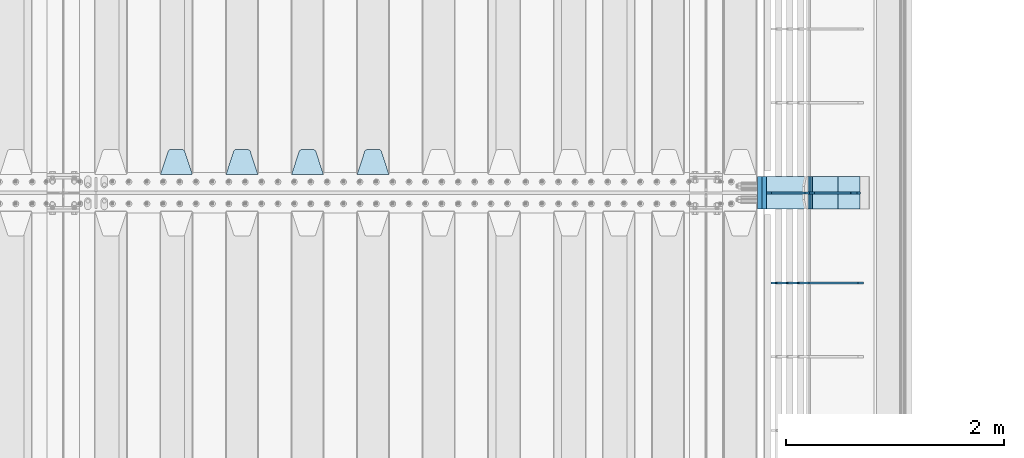
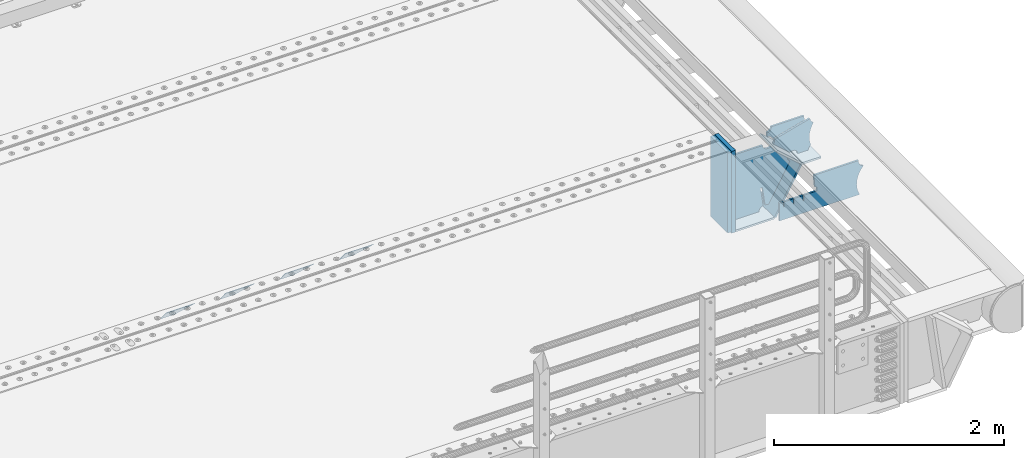
# One storey, part 244 of 270: 14 plates.
"""IFC2X3 building model written with IfcOpenShell, lengths in millimetres."""

from ifc_helpers import new_model, si_unit, frame, origin_with_axes, place, context, subcontext, project, spatial, faceted_brep, material, type_object, element, save


model = new_model("IFC2X3")

# Units and contexts
model_context = context("Model", 3, precision=1e-05, world=origin_with_axes())
body_context = subcontext(model_context, "Body", "Model", "MODEL_VIEW")
ifc_project = project(units=[si_unit("LENGTHUNIT", "METRE", prefix="MILLI"), si_unit("AREAUNIT", "SQUARE_METRE"), si_unit("VOLUMEUNIT", "CUBIC_METRE"), si_unit("MASSUNIT", "GRAM", prefix="KILO"), si_unit("TIMEUNIT", "SECOND"), si_unit("PLANEANGLEUNIT", "RADIAN"), si_unit("SOLIDANGLEUNIT", "STERADIAN"), si_unit("THERMODYNAMICTEMPERATUREUNIT", "DEGREE_CELSIUS"), si_unit("LUMINOUSINTENSITYUNIT", "LUMEN")], contexts=[model_context])

# Site, building, storey
site_placement = place(None, origin_with_axes())
site = spatial("IfcSite", under=ifc_project, at=site_placement, CompositionType="ELEMENT")
building_placement = place(site_placement, origin_with_axes())
building = spatial("IfcBuilding", under=site, at=building_placement, Name="Standard", CompositionType="ELEMENT")
storey_placement = place(building_placement, origin_with_axes())
storey = spatial("IfcBuildingStorey", under=building, at=storey_placement, Name="Undefined", CompositionType="ELEMENT", Elevation=0.0)

# Plates
ifc_material_1 = material(Name="STEEL/S355N")
plate_type_1 = type_object("IfcPlateType", PredefinedType="NOTDEFINED")
plate_1_placement = place(storey_placement, frame((17015.0, -20831.767766953, -1.76776695296758), z_axis=(0.0, 0.707106781186547, -0.707106781186548), x_axis=(-1.0, 0.0, 0.0)))
element("IfcPlate", 1, at=plate_1_placement, inside=storey, type_object=plate_type_1, material=ifc_material_1, context=body_context, shape_type="Brep", body=[
    faceted_brep([(0.0, -2.5, 0.0), (69.345504679477, -2.5, 300.171731424831), (69.345504679477, 2.5, 300.171731424831), (0.0, 2.5, 0.0), (70.9274061199576, -2.5, 304.8974424154), (70.9274061199576, 2.5, 304.8974424154), (73.3818627772307, -2.49999999999818, 309.234538108527), (73.3818627772307, 2.50000000000182, 309.234538108527), (76.6187032999551, -2.5, 313.023683126103), (76.6187032999551, 2.5, 313.023683126103), (80.5190132704993, -2.5, 316.125672595372), (80.5190132704993, 2.50000000000182, 316.125672595372), (84.9395038596849, -2.49999999999818, 318.426546230476), (84.9395038596849, 2.5, 318.426546230476), (89.7177759439219, -2.49999999999818, 319.841774983275), (89.7177759439219, 2.50000000000182, 319.841774983275), (94.678286292652, -2.5, 320.319366455078), (94.678286292652, 2.5, 320.319366455078), (195.321713707348, -2.5, 320.319366455078), (195.321713707348, 2.5, 320.319366455078), (200.282224056078, -2.49999999999818, 319.841774983275), (200.282224056078, 2.50000000000182, 319.841774983275), (205.060496140315, -2.5, 318.426546230476), (205.060496140315, 2.5, 318.426546230476), (209.480986729501, -2.5, 316.12567259537), (209.480986729501, 2.50000000000182, 316.12567259537), (213.381296700045, -2.5, 313.023683126103), (213.381296700045, 2.5, 313.023683126103), (216.618137222769, -2.49999999999818, 309.234538108525), (216.618137222769, 2.50000000000182, 309.234538108527), (219.072593880042, -2.49999999999818, 304.897442415398), (219.072593880042, 2.50000000000182, 304.897442415397), (220.654495320523, -2.5, 300.171731424831), (220.654495320523, 2.5, 300.171731424831), (290.0, -2.49999999999818, 0.0), (290.0, 2.5, 0.0)], [[[0, 1, 2, 3]], [[1, 4, 5, 2]], [[4, 6, 7, 5]], [[6, 8, 9, 7]], [[8, 10, 11, 9]], [[10, 12, 13, 11]], [[12, 14, 15, 13]], [[14, 16, 17, 15]], [[16, 18, 19, 17]], [[18, 20, 21, 19]], [[20, 22, 23, 21]], [[22, 24, 25, 23]], [[24, 26, 27, 25]], [[26, 28, 29, 27]], [[28, 30, 31, 29]], [[30, 32, 33, 31]], [[32, 34, 35, 33]], [[34, 0, 3, 35]], [[5, 7, 9, 11, 13, 15, 17, 19, 21, 23, 25, 27, 29, 31, 33, 35, 3, 2]], [[34, 32, 30, 28, 26, 24, 22, 20, 18, 16, 14, 12, 10, 8, 6, 4, 1, 0]]]),
])
plate_2_placement = place(storey_placement, frame((16415.0, -20831.767766953, -1.76776695296758), z_axis=(0.0, 0.707106781186547, -0.707106781186548), x_axis=(-1.0, 0.0, 0.0)))
element("IfcPlate", 2, at=plate_2_placement, inside=storey, type_object=plate_type_1, material=ifc_material_1, context=body_context, shape_type="Brep", body=[
    faceted_brep([(0.0, -2.5, 0.0), (69.345504679477, -2.5, 300.171731424831), (69.345504679477, 2.5, 300.171731424831), (0.0, 2.5, 0.0), (70.9274061199576, -2.5, 304.8974424154), (70.9274061199576, 2.5, 304.8974424154), (73.3818627772307, -2.49999999999818, 309.234538108527), (73.3818627772307, 2.50000000000182, 309.234538108527), (76.6187032999551, -2.5, 313.023683126103), (76.6187032999551, 2.5, 313.023683126103), (80.5190132704993, -2.5, 316.125672595372), (80.5190132704993, 2.50000000000182, 316.125672595372), (84.9395038596849, -2.49999999999818, 318.426546230476), (84.9395038596849, 2.5, 318.426546230476), (89.7177759439219, -2.49999999999818, 319.841774983275), (89.7177759439219, 2.50000000000182, 319.841774983275), (94.678286292652, -2.5, 320.319366455078), (94.678286292652, 2.5, 320.319366455078), (195.321713707348, -2.5, 320.319366455078), (195.321713707348, 2.5, 320.319366455078), (200.282224056078, -2.49999999999818, 319.841774983275), (200.282224056078, 2.50000000000182, 319.841774983275), (205.060496140315, -2.5, 318.426546230476), (205.060496140315, 2.5, 318.426546230476), (209.480986729501, -2.5, 316.12567259537), (209.480986729501, 2.50000000000182, 316.12567259537), (213.381296700045, -2.5, 313.023683126103), (213.381296700045, 2.5, 313.023683126103), (216.618137222769, -2.49999999999818, 309.234538108525), (216.618137222769, 2.50000000000182, 309.234538108527), (219.072593880042, -2.49999999999818, 304.897442415398), (219.072593880042, 2.50000000000182, 304.897442415397), (220.654495320523, -2.5, 300.171731424831), (220.654495320523, 2.5, 300.171731424831), (290.0, -2.49999999999818, 0.0), (290.0, 2.5, 0.0)], [[[0, 1, 2, 3]], [[1, 4, 5, 2]], [[4, 6, 7, 5]], [[6, 8, 9, 7]], [[8, 10, 11, 9]], [[10, 12, 13, 11]], [[12, 14, 15, 13]], [[14, 16, 17, 15]], [[16, 18, 19, 17]], [[18, 20, 21, 19]], [[20, 22, 23, 21]], [[22, 24, 25, 23]], [[24, 26, 27, 25]], [[26, 28, 29, 27]], [[28, 30, 31, 29]], [[30, 32, 33, 31]], [[32, 34, 35, 33]], [[34, 0, 3, 35]], [[5, 7, 9, 11, 13, 15, 17, 19, 21, 23, 25, 27, 29, 31, 33, 35, 3, 2]], [[34, 32, 30, 28, 26, 24, 22, 20, 18, 16, 14, 12, 10, 8, 6, 4, 1, 0]]]),
])
plate_3_placement = place(storey_placement, frame((15815.0, -20831.767766953, -1.76776695296758), z_axis=(0.0, 0.707106781186547, -0.707106781186548), x_axis=(-1.0, 0.0, 0.0)))
element("IfcPlate", 3, at=plate_3_placement, inside=storey, type_object=plate_type_1, material=ifc_material_1, context=body_context, shape_type="Brep", body=[
    faceted_brep([(0.0, -2.5, 0.0), (69.345504679477, -2.5, 300.171731424831), (69.345504679477, 2.5, 300.171731424831), (0.0, 2.5, 0.0), (70.9274061199576, -2.5, 304.8974424154), (70.9274061199576, 2.5, 304.8974424154), (73.3818627772307, -2.49999999999818, 309.234538108527), (73.3818627772307, 2.50000000000182, 309.234538108527), (76.6187032999551, -2.5, 313.023683126103), (76.6187032999551, 2.5, 313.023683126103), (80.5190132704993, -2.5, 316.125672595372), (80.5190132704993, 2.50000000000182, 316.125672595372), (84.9395038596849, -2.49999999999818, 318.426546230476), (84.9395038596849, 2.5, 318.426546230476), (89.7177759439219, -2.49999999999818, 319.841774983275), (89.7177759439219, 2.50000000000182, 319.841774983275), (94.678286292652, -2.5, 320.319366455078), (94.678286292652, 2.5, 320.319366455078), (195.321713707348, -2.5, 320.319366455078), (195.321713707348, 2.5, 320.319366455078), (200.282224056078, -2.49999999999818, 319.841774983275), (200.282224056078, 2.50000000000182, 319.841774983275), (205.060496140315, -2.5, 318.426546230476), (205.060496140315, 2.5, 318.426546230476), (209.480986729501, -2.5, 316.12567259537), (209.480986729501, 2.50000000000182, 316.12567259537), (213.381296700045, -2.5, 313.023683126103), (213.381296700045, 2.5, 313.023683126103), (216.618137222769, -2.49999999999818, 309.234538108525), (216.618137222769, 2.50000000000182, 309.234538108527), (219.072593880042, -2.49999999999818, 304.897442415398), (219.072593880042, 2.50000000000182, 304.897442415397), (220.654495320523, -2.5, 300.171731424831), (220.654495320523, 2.5, 300.171731424831), (290.0, -2.49999999999818, 0.0), (290.0, 2.5, 0.0)], [[[0, 1, 2, 3]], [[1, 4, 5, 2]], [[4, 6, 7, 5]], [[6, 8, 9, 7]], [[8, 10, 11, 9]], [[10, 12, 13, 11]], [[12, 14, 15, 13]], [[14, 16, 17, 15]], [[16, 18, 19, 17]], [[18, 20, 21, 19]], [[20, 22, 23, 21]], [[22, 24, 25, 23]], [[24, 26, 27, 25]], [[26, 28, 29, 27]], [[28, 30, 31, 29]], [[30, 32, 33, 31]], [[32, 34, 35, 33]], [[34, 0, 3, 35]], [[5, 7, 9, 11, 13, 15, 17, 19, 21, 23, 25, 27, 29, 31, 33, 35, 3, 2]], [[34, 32, 30, 28, 26, 24, 22, 20, 18, 16, 14, 12, 10, 8, 6, 4, 1, 0]]]),
])
plate_4_placement = place(storey_placement, frame((15215.0, -20831.767766953, -1.76776695296758), z_axis=(0.0, 0.707106781186547, -0.707106781186548), x_axis=(-1.0, 0.0, 0.0)))
element("IfcPlate", 4, at=plate_4_placement, inside=storey, type_object=plate_type_1, material=ifc_material_1, context=body_context, shape_type="Brep", body=[
    faceted_brep([(0.0, -2.5, 0.0), (69.345504679477, -2.5, 300.171731424831), (69.345504679477, 2.5, 300.171731424831), (0.0, 2.5, 0.0), (70.9274061199576, -2.5, 304.8974424154), (70.9274061199576, 2.5, 304.8974424154), (73.3818627772307, -2.49999999999818, 309.234538108527), (73.3818627772307, 2.50000000000182, 309.234538108527), (76.6187032999551, -2.5, 313.023683126103), (76.6187032999551, 2.5, 313.023683126103), (80.5190132704993, -2.5, 316.125672595372), (80.5190132704993, 2.50000000000182, 316.125672595372), (84.9395038596849, -2.49999999999818, 318.426546230476), (84.9395038596849, 2.5, 318.426546230476), (89.7177759439219, -2.49999999999818, 319.841774983275), (89.7177759439219, 2.50000000000182, 319.841774983275), (94.678286292652, -2.5, 320.319366455078), (94.678286292652, 2.5, 320.319366455078), (195.321713707348, -2.5, 320.319366455078), (195.321713707348, 2.5, 320.319366455078), (200.282224056078, -2.49999999999818, 319.841774983275), (200.282224056078, 2.50000000000182, 319.841774983275), (205.060496140315, -2.5, 318.426546230476), (205.060496140315, 2.5, 318.426546230476), (209.480986729501, -2.5, 316.12567259537), (209.480986729501, 2.50000000000182, 316.12567259537), (213.381296700045, -2.5, 313.023683126103), (213.381296700045, 2.5, 313.023683126103), (216.618137222769, -2.49999999999818, 309.234538108525), (216.618137222769, 2.50000000000182, 309.234538108527), (219.072593880042, -2.49999999999818, 304.897442415398), (219.072593880042, 2.50000000000182, 304.897442415397), (220.654495320523, -2.5, 300.171731424831), (220.654495320523, 2.5, 300.171731424831), (290.0, -2.49999999999818, 0.0), (290.0, 2.5, 0.0)], [[[0, 1, 2, 3]], [[1, 4, 5, 2]], [[4, 6, 7, 5]], [[6, 8, 9, 7]], [[8, 10, 11, 9]], [[10, 12, 13, 11]], [[12, 14, 15, 13]], [[14, 16, 17, 15]], [[16, 18, 19, 17]], [[18, 20, 21, 19]], [[20, 22, 23, 21]], [[22, 24, 25, 23]], [[24, 26, 27, 25]], [[26, 28, 29, 27]], [[28, 30, 31, 29]], [[30, 32, 33, 31]], [[32, 34, 35, 33]], [[34, 0, 3, 35]], [[5, 7, 9, 11, 13, 15, 17, 19, 21, 23, 25, 27, 29, 31, 33, 35, 3, 2]], [[34, 32, 30, 28, 26, 24, 22, 20, 18, 16, 14, 12, 10, 8, 6, 4, 1, 0]]]),
])
plate_type_2 = type_object("IfcPlateType", PredefinedType="NOTDEFINED")
plate_5_placement = place(storey_placement, frame((20872.9988298914, -20999.9999999999, -179.999999999866), z_axis=(0.0, 0.0, -1.0), x_axis=(-1.0, 0.0, 0.0)))
element("IfcPlate", 5, at=plate_5_placement, inside=storey, type_object=plate_type_2, material=ifc_material_1, context=body_context, shape_type="Brep", body=[
    faceted_brep([(46.0258547361445, 10.0, 641.078828352486), (73.3015011074785, 10.0000000000073, 445.179898435767), (73.3015011074785, -9.99999999998909, 445.179898435767), (46.0258547361445, -10.0, 641.078828352486), (53.4925862871278, 10.0000000000073, 442.421838675718), (53.4925862871278, -9.99999999998909, 442.421838675718), (25.7820501123933, 10.0, 641.444230671287), (25.7820501123933, -10.0, 641.444230671287), (54.6652503111618, 10.0, 642.447174185377), (54.6652503111618, -10.0, 642.447174185377), (68.6036632070354, -10.0, 649.549150281387), (68.6036632070354, 10.0, 649.549150281387), (79.6652503111618, -10.0, 660.610737385511), (79.6652503111618, 10.0, 660.610737385511), (86.7672264071698, -10.0, 674.549150281387), (86.7672264071698, 10.0, 674.549150281387), (89.2144005924129, -10.0, 690.0), (89.2144005924129, 10.0, 690.0), (353.0, -10.0, 690.0), (353.0, 10.0, 690.0), (355.447174185243, -10.0, 674.549150281253), (355.447174185243, 10.0, 674.549150281253), (362.549150281251, -10.0, 660.610737385376), (362.549150281251, 10.0, 660.610737385376), (373.610737385377, -10.0, 649.549150281253), (373.610737385377, 10.0, 649.549150281253), (387.549150281251, -10.0, 642.447174185242), (387.549150281251, 10.0, 642.447174185242), (403.0, -10.0, 640.0), (403.0, 10.0, 640.0), (403.0, -10.0, 50.0), (403.0, 10.0, 50.0), (387.549150281251, -10.0, 47.5528258147577), (387.549150281251, 10.0, 47.5528258147577), (373.610737385377, -10.0, 40.4508497187474), (373.610737385377, 10.0, 40.4508497187474), (362.549150281251, -10.0, 29.3892626146236), (362.549150281251, 10.0, 29.3892626146236), (355.447174185243, -10.0, 15.4508497187474), (355.447174185243, 10.0, 15.4508497187474), (353.0, -10.0, 0.0), (353.0, 10.0, 0.0), (50.0, -10.0, 0.0), (50.0, 10.0, 0.0), (47.0349915316328, -10.0, 16.9620037619133), (47.0349915316328, 10.0, 16.9620037619133), (38.4916171352343, -10.0, 31.9123081320451), (38.4916171352343, 10.0, 31.9123081320451), (25.3831239081519, -10.0, 43.0778019479116), (25.3831239081519, 10.0, 43.0778019479116), (9.26418358741648, -10.0, 49.1342538608113), (9.26418358741648, 10.0, 49.1342538608113), (-7.95349204488593, -10.0, 49.363366622344), (-7.95349204488593, 10.0, 49.363366622344), (-24.2278808265401, -10.0, 43.7379673813837), (-24.2278808265401, 10.0, 43.7379673813837), (-37.6288347353438, -10.0, 32.9252303934259), (-37.6288347353438, 10.0, 32.9252303934259), (-210.371165264656, -10.0, 184.074769606574), (-210.371165264656, 10.0, 184.074769606574), (-202.382363280569, -10.0, 196.529747922069), (-202.382363280569, 10.0, 196.529747922069), (-198.388707244045, -10.0, 210.777489969227), (-198.388707244045, 10.0, 210.777489969227), (-198.739957464426, -10.0, 225.570193077959), (-198.739957464426, 10.0, 225.570193077959), (-203.40535180681, -10.0, 239.612327446012), (-203.40535180681, 10.0, 239.612327446012), (-211.976299808361, -10.0, 251.674097313455), (-211.976299808361, 10.0, 251.674097313455), (-223.702166612962, -10.0, 260.699145216992), (-223.702166612962, 10.0, 260.699145216992), (-9.29783338703783, -10.0, 646.300854783008), (-9.29783338703783, 10.0, 646.300854783008), (6.98069453597782, -10.0, 640.647282345602), (6.98069453597782, 10.0, 640.647282345602), (24.2117663163663, -10.0, 640.855891896051), (24.2117663163663, 10.0, 640.855891896051)], [[[0, 1, 2, 3]], [[4, 5, 2, 1]], [[6, 7, 5, 4]], [[8, 9, 10, 11]], [[11, 10, 12, 13]], [[13, 12, 14, 15]], [[15, 14, 16, 17]], [[18, 19, 17, 16]], [[18, 20, 21, 19]], [[20, 22, 23, 21]], [[22, 24, 25, 23]], [[24, 26, 27, 25]], [[26, 28, 29, 27]], [[28, 30, 31, 29]], [[30, 32, 33, 31]], [[32, 34, 35, 33]], [[34, 36, 37, 35]], [[36, 38, 39, 37]], [[38, 40, 41, 39]], [[40, 42, 43, 41]], [[42, 44, 45, 43]], [[44, 46, 47, 45]], [[46, 48, 49, 47]], [[48, 50, 51, 49]], [[50, 52, 53, 51]], [[52, 54, 55, 53]], [[54, 56, 57, 55]], [[56, 58, 59, 57]], [[58, 60, 61, 59]], [[60, 62, 63, 61]], [[62, 64, 65, 63]], [[64, 66, 67, 65]], [[66, 68, 69, 67]], [[68, 70, 71, 69]], [[70, 72, 73, 71]], [[72, 74, 75, 73]], [[74, 76, 77, 75]], [[1, 0, 8, 11, 13, 15, 17, 19, 21, 23, 25, 27, 29, 31, 33, 35, 37, 39, 41, 43, 45, 47, 49, 51, 53, 55, 57, 59, 61, 63, 65, 67, 69, 71, 73, 75, 77, 6, 4]], [[9, 8, 0, 3]], [[76, 74, 72, 70, 68, 66, 64, 62, 60, 58, 56, 54, 52, 50, 48, 46, 44, 42, 40, 38, 36, 34, 32, 30, 28, 26, 24, 22, 20, 18, 16, 14, 12, 10, 9, 3, 2, 5, 7]], [[77, 76, 7, 6]]]),
])
plate_type_3 = type_object("IfcPlateType", PredefinedType="NOTDEFINED")
plate_6_placement = place(storey_placement, frame((21413.9988502513, -21000.0000000007, -28.9999913318487), z_axis=(0.260769276985653, 0.0, -0.965401151946889), x_axis=(-0.965401151946889, 0.0, -0.260769276985654)))
element("IfcPlate", 6, at=plate_6_placement, inside=storey, type_object=plate_type_3, material=ifc_material_1, context=body_context, shape_type="Brep", body=[
    faceted_brep([(183.436474692327, 10.0, 275.852500330424), (184.918388609061, 10.0, 264.417843531322), (184.918388609061, -10.0, 264.417843531322), (183.436474692327, -10.0, 275.852500330424), (183.794583267612, 10.0, 224.576469334607), (183.794583267612, -10.0, 224.576469334607), (176.452049775839, 10.0, 185.401410454621), (176.452049775839, -10.0, 185.401410454621), (163.071585676767, 10.0, 147.857286855558), (163.071585676767, -10.0, 147.857286855558), (143.982662403749, 10.0, 112.868559462227), (143.982662403749, -10.0, 112.868559462227), (119.655312600251, 10.0, 81.2967668639831), (119.655312600251, -10.0, 81.2967668639831), (100.960891712748, 10.0, 63.6280409830933), (100.960891712748, -10.0, 63.6280409830933), (194.486836975902, -10.0, 278.751956446687), (207.178624553377, -10.0, 286.650994937514), (207.178624553377, 10.0, 286.650994937514), (194.486836975902, 10.0, 278.751956446687), (216.968013469446, -10.0, 297.948965801394), (216.968013469446, 10.0, 297.948965801394), (222.979925232863, -10.0, 311.635937633766), (222.979925232863, 10.0, 311.635937633766), (323.381647032762, -10.0, 284.515917834983), (323.381647032762, 10.0, 284.515917834983), (321.720617177336, -10.0, 268.853198956859), (321.720617177336, 10.0, 268.853198956859), (325.01434448114, -10.0, 253.450889283181), (325.01434448114, 10.0, 253.450889283181), (332.935986082481, -10.0, 239.837389469553), (332.935986082481, 10.0, 239.837389469553), (344.699462330093, -10.0, 229.363593146935), (344.699462330093, 10.0, 229.363593146935), (359.137460970807, -10.0, 223.0688351622), (359.137460970807, 10.0, 223.0688351622), (374.817271777687, -10.0, 221.57775639289), (374.817271777687, 10.0, 221.57775639289), (390.182952880859, -10.0, 225.038330078124), (390.182952880859, 10.0, 225.038330078124), (512.909060513026, -10.0, 41.5599003357011), (512.909060513026, 10.0, 41.5599003357011), (503.648024844581, -10.0, 33.5643666747665), (503.648024844581, 10.0, 33.5643666747665), (496.606064569703, -10.0, 23.5590612989981), (496.606064569703, 10.0, 23.5590612989981), (492.204839143935, -10.0, 12.1430832451069), (492.204839143935, 10.0, 12.1430832451069), (490.707885742184, -10.0, 3.79259290639311e-10), (490.707885742184, 10.0, 3.79259290639311e-10), (120.0, -10.0, 9.18589648790658e-11), (120.0, 10.0, 9.18589648790658e-11), (117.226254779114, -10.0, 25.6516118492136), (117.226254779114, 10.0, 25.6516118492136), (109.03324682566, -10.0, 50.1173731020972), (109.03324682566, 10.0, 50.1173731020972)], [[[0, 1, 2, 3]], [[4, 5, 2, 1]], [[6, 7, 5, 4]], [[8, 9, 7, 6]], [[10, 11, 9, 8]], [[12, 13, 11, 10]], [[14, 15, 13, 12]], [[16, 17, 18, 19]], [[17, 20, 21, 18]], [[20, 22, 23, 21]], [[22, 24, 25, 23]], [[24, 26, 27, 25]], [[26, 28, 29, 27]], [[28, 30, 31, 29]], [[30, 32, 33, 31]], [[32, 34, 35, 33]], [[34, 36, 37, 35]], [[36, 38, 39, 37]], [[38, 40, 41, 39]], [[40, 42, 43, 41]], [[42, 44, 45, 43]], [[44, 46, 47, 45]], [[46, 48, 49, 47]], [[48, 50, 51, 49]], [[50, 52, 53, 51]], [[52, 54, 55, 53]], [[10, 8, 6, 4, 1, 0, 19, 18, 21, 23, 25, 27, 29, 31, 33, 35, 37, 39, 41, 43, 45, 47, 49, 51, 53, 55, 14, 12]], [[16, 19, 0, 3]], [[54, 52, 50, 48, 46, 44, 42, 40, 38, 36, 34, 32, 30, 28, 26, 24, 22, 20, 17, 16, 3, 2, 5, 7, 9, 11, 13, 15]], [[55, 54, 15, 14]]]),
])
plate_type_4 = type_object("IfcPlateType", PredefinedType="NOTDEFINED")
plate_7_placement = place(storey_placement, frame((20885.2260590443, -20850.0000000007, -177.219372761326), z_axis=(0.752414935148685, 0.0, -0.658689430130164), x_axis=(0.0, -1.0, 0.0)))
element("IfcPlate", 7, at=plate_7_placement, inside=storey, type_object=plate_type_4, material=ifc_material_1, context=body_context, shape_type="Brep", body=[
    faceted_brep([(0.0, -10.0, 0.0), (1.09139364212751e-10, -10.0000000000055, 320.0), (1.09139364212751e-10, 9.99999999999818, 319.999999999998), (0.0, 10.0, 0.0), (300.0, -10.0000000000055, 320.0), (300.0, 9.99999999999818, 319.999999999998), (300.0, -10.0000000000018, 6.54836185276508e-11), (300.0, 9.99999999999636, 6.54836185276508e-11)], [[[0, 1, 2, 3]], [[1, 4, 5, 2]], [[4, 6, 7, 5]], [[6, 0, 3, 7]], [[5, 7, 3, 2]], [[6, 4, 1, 0]]]),
])
plate_8_placement = place(storey_placement, frame((21126.0007288109, -20849.9999999999, -408.004820491625), z_axis=(-0.484064236150485, 0.0, -0.875032465272031), x_axis=(0.0, -1.0, 0.0)))
element("IfcPlate", 8, at=plate_8_placement, inside=storey, type_object=plate_type_4, material=ifc_material_1, context=body_context, shape_type="Brep", body=[
    faceted_brep([(0.0, -10.0, 0.0), (3.86513420380652e-07, -10.0, 533.528442382813), (3.86513420380652e-07, 9.99999999999636, 533.528442382813), (0.0, 10.0, 0.0), (300.003295898438, -10.0, 533.549133300781), (300.003295898438, 9.99999999999636, 533.549133300781), (300.0, -10.0000000000018, 6.54836185276508e-11), (300.0, 9.99999999999636, 6.54836185276508e-11)], [[[0, 1, 2, 3]], [[1, 4, 5, 2]], [[4, 6, 7, 5]], [[6, 0, 3, 7]], [[5, 7, 3, 2]], [[6, 4, 1, 0]]]),
])
plate_9_placement = place(storey_placement, frame((20469.9988298914, -20849.9999999999, -879.999999999866), z_axis=(0.0, -1.0, 0.0), x_axis=(1.0, 0.0, 0.0)))
element("IfcPlate", 9, at=plate_9_placement, inside=storey, type_object=plate_type_4, material=ifc_material_1, context=body_context, shape_type="Brep", body=[
    faceted_brep([(0.0, -10.0, 0.0), (-1.98724592337385e-10, -10.0000000000036, 300.0), (-1.98724592337385e-10, 10.0, 300.0), (0.0, 10.0, 0.0), (389.0, -10.0, 300.0), (389.0, 10.0, 300.0), (389.0, -10.0, 0.0), (389.0, 10.0, 0.0)], [[[0, 1, 2, 3]], [[1, 4, 5, 2]], [[4, 6, 7, 5]], [[6, 0, 3, 7]], [[5, 7, 3, 2]], [[6, 4, 1, 0]]]),
])
plate_type_5 = type_object("IfcPlateType", PredefinedType="NOTDEFINED")
plate_10_placement = place(storey_placement, frame((21329.9988298914, -20850.0000000007, -397.999999999763), z_axis=(-1.0, 0.0, 0.0), x_axis=(0.0, -1.0, 0.0)))
element("IfcPlate", 10, at=plate_10_placement, inside=storey, type_object=plate_type_5, material=ifc_material_1, context=body_context, shape_type="Brep", body=[
    faceted_brep([(0.0, -10.0, 0.0), (4.65661287307739e-10, -10.0, 204.0), (4.65661287307739e-10, 10.0, 204.0), (0.0, 10.0, 0.0), (300.0, -10.0, 204.0), (300.0, 10.0, 204.0), (300.0, -10.0000000000018, 6.54836185276508e-11), (300.0, 9.99999999999636, 6.54836185276508e-11)], [[[0, 1, 2, 3]], [[1, 4, 5, 2]], [[4, 6, 7, 5]], [[6, 0, 3, 7]], [[5, 7, 3, 2]], [[6, 4, 1, 0]]]),
])
ifc_material_2 = material()
plate_type_6 = type_object("IfcPlateType", PredefinedType="NOTDEFINED")
plate_11_placement = place(storey_placement, frame((20449.9988298906, -20850.0, -889.999999999995), z_axis=(0.0, 0.0, 1.0), x_axis=(0.0, -1.0, 0.0)))
element("IfcPlate", 11, at=plate_11_placement, inside=storey, type_object=plate_type_6, material=ifc_material_2, context=body_context, shape_type="Brep", body=[
    faceted_brep([(0.0, -20.0, 0.0), (0.0, -20.0, 870.0), (0.0, 20.0, 870.0), (0.0, 20.0, 0.0), (300.0, -20.0, 870.0), (300.0, 20.0, 870.0), (300.0, -20.0, -1.81898940354586e-12), (300.0, 20.0, -1.81898940354586e-12)], [[[0, 1, 2, 3]], [[1, 4, 5, 2]], [[4, 6, 7, 5]], [[6, 0, 3, 7]], [[5, 7, 3, 2]], [[6, 4, 1, 0]]]),
])
plate_12_placement = place(storey_placement, frame((20410.0, -20850.0, -875.0), z_axis=(0.0, 0.0, 1.0), x_axis=(0.0, -1.0, 0.0)))
element("IfcPlate", 12, at=plate_12_placement, inside=storey, type_object=plate_type_6, material=ifc_material_2, context=body_context, shape_type="Brep", body=[
    faceted_brep([(0.0, -20.0, 0.0), (0.0, -20.0, 850.0), (0.0, 20.0, 850.0), (0.0, 20.0, 0.0), (300.0, -20.0, 850.0), (300.0, 20.0, 850.0), (300.0, -20.0, -1.81898940354586e-12), (300.0, 20.0, -1.81898940354586e-12)], [[[0, 1, 2, 3]], [[1, 4, 5, 2]], [[4, 6, 7, 5]], [[6, 0, 3, 7]], [[5, 7, 3, 2]], [[6, 4, 1, 0]]]),
])
plate_type_7 = type_object("IfcPlateType", PredefinedType="NOTDEFINED")
plate_13_placement = place(storey_placement, frame((21408.9988298906, -21000.0, -9.99999999999716), z_axis=(0.0, 0.0, -1.0), x_axis=(-1.0, 0.0, 0.0)))
element("IfcPlate", 13, at=plate_13_placement, inside=storey, type_object=plate_type_7, material=ifc_material_1, context=body_context, shape_type="Brep", body=[
    faceted_brep([(164.157641141064, -10.0, 44.1844865875018), (486.718340840864, -10.0, 131.004562768382), (486.718340840864, 10.0, 131.004562768382), (164.157641141064, 10.0, 44.1844865875018), (492.179177700767, -10.0, 118.185717565315), (492.179177700767, 10.0, 118.185717565315), (500.965368826703, -10.0, 107.371542744776), (500.965368826703, 10.0, 107.371542744776), (512.394601349042, -10.0, 99.4018391429503), (512.394601349042, 10.0, 99.4018391429503), (525.579310641864, -10.0, 94.8955133209048), (525.579310641864, 10.0, 94.8955133209048), (539.495606295339, -10.0, 94.2025148824028), (539.495606295339, 10.0, 94.2025148824028), (543.504393704661, -10.0, 49.7974851175972), (543.504393704661, 10.0, 49.7974851175972), (529.167086307516, -10.0, 46.3176139481669), (529.167086307516, 10.0, 46.3176139481669), (516.469507120331, -10.0, 38.8049999196639), (516.469507120331, 10.0, 38.8049999196639), (506.517198234546, -10.0, 27.9137449599276), (506.517198234546, 10.0, 27.9137449599276), (500.17667886756, -10.0, 14.592119649441), (500.17667886756, 10.0, 14.592119649441), (498.0, -10.0, 0.0), (498.0, 10.0, 0.0), (170.0, -10.0, 0.0), (170.0, 10.0, 0.0), (169.632873911985, -10.0, 11.1663820622718), (169.632873911985, 10.0, 11.1663820622718), (168.533081313406, -10.0, 22.2845350637931), (168.533081313406, 10.0, 22.2845350637931), (166.705372351957, -10.0, 33.3064382514178), (166.705372351957, 10.0, 33.3064382514178)], [[[0, 1, 2, 3]], [[1, 4, 5, 2]], [[4, 6, 7, 5]], [[6, 8, 9, 7]], [[8, 10, 11, 9]], [[10, 12, 13, 11]], [[12, 14, 15, 13]], [[14, 16, 17, 15]], [[16, 18, 19, 17]], [[18, 20, 21, 19]], [[20, 22, 23, 21]], [[22, 24, 25, 23]], [[24, 26, 27, 25]], [[26, 28, 29, 27]], [[28, 30, 31, 29]], [[30, 32, 33, 31]], [[32, 0, 3, 33]], [[5, 7, 9, 11, 13, 15, 17, 19, 21, 23, 25, 27, 29, 31, 33, 3, 2]], [[32, 30, 28, 26, 24, 22, 20, 18, 16, 14, 12, 10, 8, 6, 4, 1, 0]]]),
])
plate_type_8 = type_object("IfcPlateType", PredefinedType="NOTDEFINED")
plate_14_placement = place(storey_placement, frame((21355.9182339676, -21825.0007171631, -374.002067436517), z_axis=(0.0, 0.0, 1.0), x_axis=(-1.0, 0.0, 0.0)))
element("IfcPlate", 14, at=plate_14_placement, inside=storey, type_object=plate_type_8, material=ifc_material_1, context=body_context, shape_type="Brep", body=[
    faceted_brep([(801.919404066546, -10.0, 188.0), (801.919404066546, 10.0, 188.0), (801.919404066546, 10.0, 132.002067436952), (801.919404066546, -10.0, 132.002067436952), (793.919404066546, 10.0, 132.002067436952), (793.919404066546, -10.0, 132.002067436952), (793.919404066546, 10.0, 180.002067436952), (793.919404066546, -10.0, 180.002067436952), (793.527856196906, 10.0, 182.474203391951), (793.527856196906, -10.0, 182.474203391951), (792.391540021545, 10.0, 184.704349455291), (792.391540021545, -10.0, 184.704349455291), (790.621686084887, 10.0, 186.474203391951), (790.621686084887, -10.0, 186.474203391951), (788.391540021545, 10.0, 187.610519567313), (788.391540021545, -10.0, 187.610519567313), (785.919404066546, -10.0, 188.002067436952), (785.919404066546, 10.0, 188.0), (841.0, -10.0, 188.0), (841.0, -10.0, 0.0), (841.0, 10.0, 0.0), (841.0, 10.0, 188.0), (33.3619566735979, -10.0, 0.0), (33.3619566735979, 10.0, 0.0), (36.2350612208174, -10.0, 4.68848050267013), (36.2350612208174, 10.0, 4.68848050267013), (51.4877592159428, -10.0, 41.5117508652784), (51.4877592159428, 10.0, 41.5117508652784), (60.792242588137, -10.0, 80.2677133162964), (60.792242588137, 10.0, 80.2677133162964), (63.9194040769726, -10.0, 120.002067436515), (63.9194040769726, 10.0, 120.002067436515), (60.792242588137, -10.0, 159.736421556734), (60.792242588137, 10.0, 159.736421556734), (51.4877592159428, -10.0, 198.492384007752), (51.4877592159428, 10.0, 198.492384007752), (36.2350612208174, -10.0, 235.31565437036), (36.2350612208174, 10.0, 235.31565437036), (15.4097206482074, -10.0, 269.299521518803), (15.4097206482074, 10.0, 269.299521518803), (-3.35474438098754, -10.0, 291.269887256574), (-3.35474438098754, 10.0, 291.269887256574), (-2.36881039375294, -10.0, 291.426043859339), (-2.36881039375294, 10.0, 291.426043859339), (17.1449676604716, -10.0, 301.368810393754), (17.1449676604716, 10.0, 301.368810393754), (32.6311896062471, -10.0, 316.855032339527), (32.6311896062471, 10.0, 316.855032339527), (42.573956140659, -10.0, 336.368810393754), (42.573956140659, 10.0, 336.368810393754), (46.0, -10.0, 358.0), (46.0, 10.0, 358.0), (45.0495205499174, -10.0, 364.001091067617), (45.0495205499174, 10.0, 364.001091067617), (495.040008544922, -10.0, 364.010009765625), (495.040008544922, 10.0, 364.010009765625), (483.600036621094, -10.0, 233.759994506836), (483.600036621094, 10.0, 233.759994506836), (472.0, -10.0, 233.759994506836), (472.0, 10.0, 233.759994506836), (468.909830056251, -10.0, 233.270559669787), (468.909830056251, 10.0, 233.270559669787), (466.122147477075, -10.0, 231.850164450585), (466.122147477075, 10.0, 231.850164450585), (463.909830056251, -10.0, 229.637847029761), (463.909830056251, 10.0, 229.637847029761), (462.489434837047, -10.0, 226.850164450585), (462.489434837047, 10.0, 226.850164450585), (462.0, -10.0, 223.759994506836), (462.0, 10.0, 223.759994506836), (462.0, -10.0, 198.0), (462.0, 10.0, 198.0), (462.489434837047, -10.0, 194.909830056251), (462.489434837047, 10.0, 194.909830056251), (463.909830056251, -10.0, 192.122147477075), (463.909830056251, 10.0, 192.122147477075), (466.122147477075, -10.0, 189.909830056251), (466.122147477075, 10.0, 189.909830056251), (468.909830056251, -10.0, 188.489434837048), (468.909830056251, 10.0, 188.489434837048), (472.0, -10.0, 188.0), (472.0, 10.0, 188.0), (585.919404066546, -10.0, 188.002067436952), (585.919404066546, 10.0, 188.0), (588.391540021545, -10.0, 187.610519567313), (588.391540021545, 10.0, 187.610519567313), (590.621686084887, -10.0, 186.474203391951), (590.621686084887, 10.0, 186.474203391951), (592.391540021545, -10.0, 184.704349455291), (592.391540021545, 10.0, 184.704349455291), (593.527856196906, -10.0, 182.474203391951), (593.527856196906, 10.0, 182.474203391951), (593.919404066546, -10.0, 180.002067436952), (593.919404066546, 10.0, 180.002067436952), (593.919404066546, -10.0000000000036, 132.002067436952), (593.919404066546, 10.0, 132.002067436952), (601.919404066546, -10.0000000000036, 132.002067436952), (601.919404066546, 10.0, 132.002067436952), (601.919404066546, -10.0, 188.0), (601.919404066546, 10.0, 188.0), (685.919404066546, -10.0, 188.002067436952), (685.919404066546, 10.0, 188.0), (688.391540021545, -10.0, 187.610519567313), (688.391540021545, 10.0, 187.610519567313), (690.621686084887, -10.0, 186.474203391951), (690.621686084887, 10.0, 186.474203391951), (692.391540021545, -10.0, 184.704349455291), (692.391540021545, 10.0, 184.704349455291), (693.527856196906, -10.0, 182.474203391951), (693.527856196906, 10.0, 182.474203391951), (693.919404066546, -10.0, 180.002067436952), (693.919404066546, 10.0, 180.002067436952), (693.919404066546, -10.0, 132.002067436952), (693.919404066546, 10.0, 132.002067436952), (701.919404066546, -10.0, 132.002067436952), (701.919404066546, 10.0, 132.002067436952), (701.919404066546, -10.0, 188.0), (701.919404066546, 10.0, 188.0)], [[[0, 1, 2, 3]], [[3, 2, 4, 5]], [[5, 4, 6, 7]], [[7, 6, 8, 9]], [[9, 8, 10, 11]], [[11, 10, 12, 13]], [[13, 12, 14, 15]], [[16, 15, 14, 17]], [[18, 19, 20, 21]], [[20, 19, 22, 23]], [[22, 24, 25, 23]], [[26, 27, 25, 24]], [[28, 29, 27, 26]], [[30, 31, 29, 28]], [[32, 33, 31, 30]], [[34, 35, 33, 32]], [[36, 37, 35, 34]], [[38, 39, 37, 36]], [[39, 38, 40, 41]], [[40, 42, 43, 41]], [[44, 45, 43, 42]], [[46, 47, 45, 44]], [[48, 49, 47, 46]], [[50, 51, 49, 48]], [[52, 53, 51, 50]], [[54, 55, 53, 52]], [[54, 56, 57, 55]], [[56, 58, 59, 57]], [[58, 60, 61, 59]], [[60, 62, 63, 61]], [[62, 64, 65, 63]], [[64, 66, 67, 65]], [[66, 68, 69, 67]], [[68, 70, 71, 69]], [[70, 72, 73, 71]], [[72, 74, 75, 73]], [[74, 76, 77, 75]], [[76, 78, 79, 77]], [[78, 80, 81, 79]], [[81, 80, 82, 83]], [[82, 84, 85, 83]], [[86, 87, 85, 84]], [[88, 89, 87, 86]], [[90, 91, 89, 88]], [[92, 93, 91, 90]], [[94, 95, 93, 92]], [[96, 97, 95, 94]], [[98, 99, 97, 96]], [[99, 98, 100, 101]], [[100, 102, 103, 101]], [[104, 105, 103, 102]], [[106, 107, 105, 104]], [[108, 109, 107, 106]], [[110, 111, 109, 108]], [[112, 113, 111, 110]], [[114, 115, 113, 112]], [[116, 117, 115, 114]], [[117, 116, 16, 17]], [[12, 10, 8, 6, 4, 2, 1, 21, 20, 23, 25, 27, 29, 31, 33, 35, 37, 39, 41, 43, 45, 47, 49, 51, 53, 55, 57, 59, 61, 63, 65, 67, 69, 71, 73, 75, 77, 79, 81, 83, 85, 87, 89, 91, 93, 95, 97, 99, 101, 103, 105, 107, 109, 111, 113, 115, 117, 17, 14]], [[18, 21, 1, 0]], [[116, 114, 112, 110, 108, 106, 104, 102, 100, 98, 96, 94, 92, 90, 88, 86, 84, 82, 80, 78, 76, 74, 72, 70, 68, 66, 64, 62, 60, 58, 56, 54, 52, 50, 48, 46, 44, 42, 40, 38, 36, 34, 32, 30, 28, 26, 24, 22, 19, 18, 0, 3, 5, 7, 9, 11, 13, 15, 16]]]),
])

save(model, "model.ifc")
